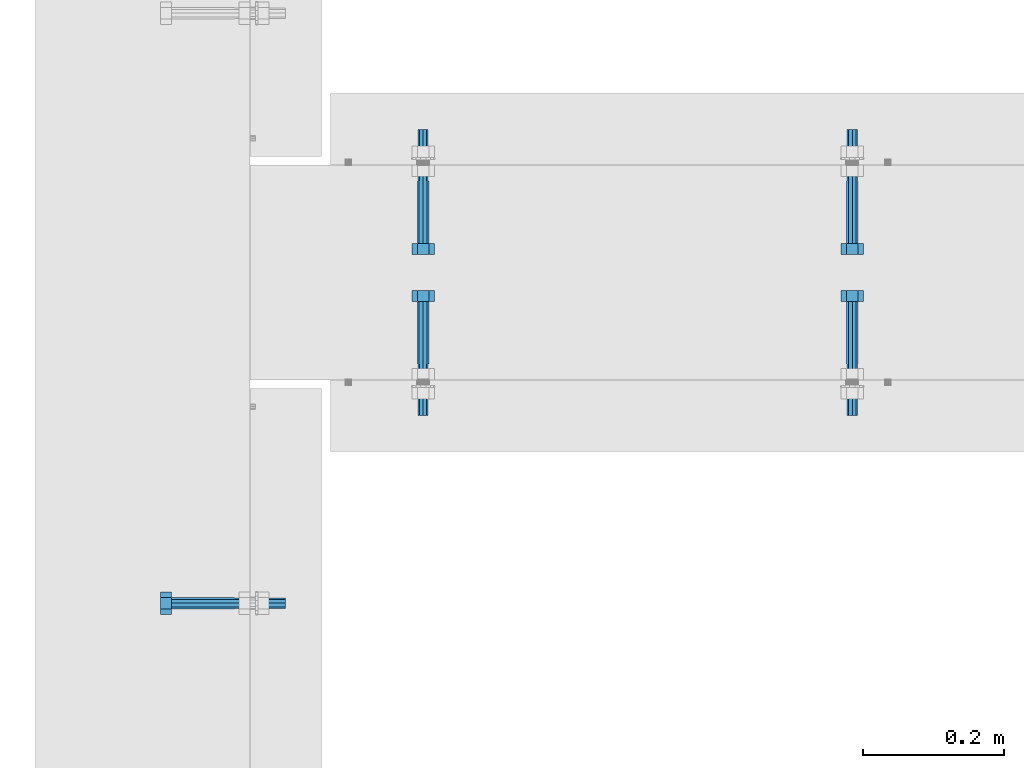
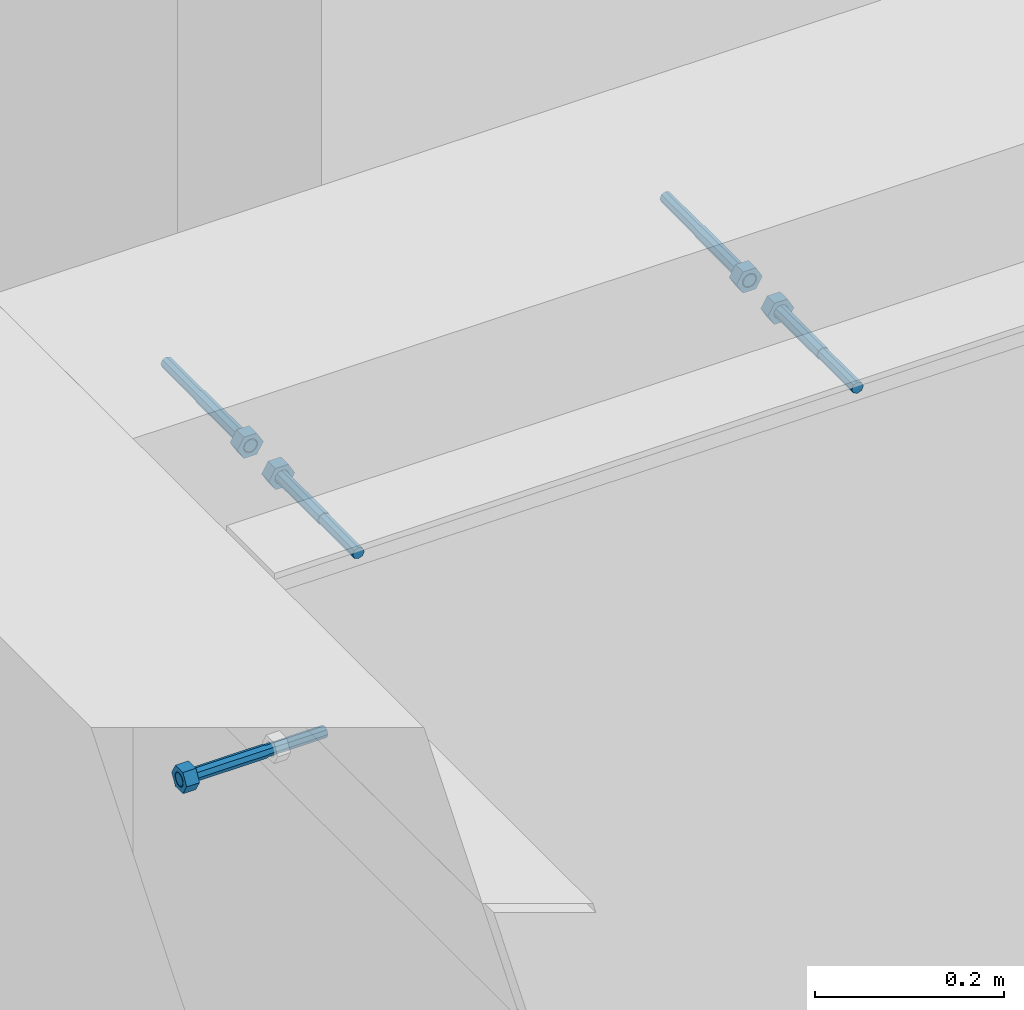
# One storey, part 420 of 975: 5 beams.
"""IFC2X3 building model written with IfcOpenShell, lengths in millimetres."""

from ifc_helpers import new_model, si_unit, frame, origin_with_axes, place, context, subcontext, project, spatial, faceted_brep, material, type_object, element, save


model = new_model("IFC2X3")

# Units and contexts
model_context = context("Model", 3, precision=1e-05, world=origin_with_axes())
body_context = subcontext(model_context, "Body", "Model", "MODEL_VIEW")
ifc_project = project(units=[si_unit("LENGTHUNIT", "METRE", prefix="MILLI"), si_unit("AREAUNIT", "SQUARE_METRE"), si_unit("VOLUMEUNIT", "CUBIC_METRE"), si_unit("MASSUNIT", "GRAM", prefix="KILO"), si_unit("TIMEUNIT", "SECOND"), si_unit("PLANEANGLEUNIT", "RADIAN"), si_unit("SOLIDANGLEUNIT", "STERADIAN"), si_unit("THERMODYNAMICTEMPERATUREUNIT", "DEGREE_CELSIUS"), si_unit("LUMINOUSINTENSITYUNIT", "LUMEN")], contexts=[model_context])

# Site, building, storey
site_placement = place(None, origin_with_axes())
site = spatial("IfcSite", under=ifc_project, at=site_placement, CompositionType="ELEMENT")
building_placement = place(site_placement, origin_with_axes())
building = spatial("IfcBuilding", under=site, at=building_placement, Name="Undefined", CompositionType="ELEMENT")
storey_placement = place(building_placement, origin_with_axes())
storey = spatial("IfcBuildingStorey", under=building, at=storey_placement, Name="Undefined", CompositionType="ELEMENT", Elevation=0.0)

# Beams
ifc_material = material(Name="STEEL/F1554-36")
beam_type = type_object("IfcBeamType", PredefinedType="NOTDEFINED")
beam_1_placement = place(storey_placement, frame((282.574949105307, 17560.9249021777, 3835.4), z_axis=(0.0, 0.0, -1.0), x_axis=(-0.999999999999998, 6.90000001668524e-08, 0.0)))
element("IfcBeam", 1, at=beam_1_placement, inside=storey, type_object=beam_type, material=ifc_material, Name="HEADED_ANCHOR_BOLT", context=body_context, shape_type="Brep", body=[
    faceted_brep([(88.9000000184824, 7.94000001861696, -13.7499999799138), (88.8999999527368, 15.8800000758411, 2.00943759409711e-08), (104.774999952569, 15.8800001213949, 6.97191353538074e-08), (104.775000018315, 7.94000006417082, -13.7499999302891), (88.900000064019, -7.94000009583215, -13.7499999799147), (104.775000063852, -7.9400000502792, -13.74999993029), (88.9000000438027, -15.880000153059, 2.00925569515675e-08), (104.775000043643, -15.8800001075042, 6.9716406869702e-08), (88.8999999780608, -7.94000009583488, 13.7500000200998), (104.774999977893, -7.94000005028101, 13.7500000697237), (88.8999999325279, 7.94000001861514, 13.7500000201007), (104.774999932361, 7.940000064169, 13.7500000697246), (88.9000000119959, 3.78780480527439, -7.86545778426807), (88.8999999957159, 6.82538844544797, -5.4430656647246), (88.8999999799416, 8.51112018845743, -1.94260763148395), (88.8999999677944, 8.51112018845652, 1.94260767167179), (88.8999999616899, 6.82538844544615, 5.44306570491244), (88.8999999628249, 3.78780480527257, 7.86545782445592), (88.8999999709849, -3.86089595849626e-08, 8.72999956233434), (88.8999999845473, -3.7878048824914, 7.8654578244541), (88.9000000008309, -6.82538852266407, 5.44306570491153), (88.9000000166052, -8.51112026567444, 1.94260767166998), (88.9000000287488, -8.51112026567353, -1.94260763148577), (88.9000000348606, -6.82538852266407, -5.44306566472642), (88.9000000337182, -3.78780488248958, -7.86545778426898), (88.9000000255583, -3.86080500902608e-08, -8.72999952214832), (104.775000025395, 6.94581103743985e-09, -8.72999947252447), (104.775000011829, 3.78780485082825, -7.86545773464422), (104.774999995549, 6.82538849100092, -5.44306561510075), (104.774999979774, 8.51112023401038, -1.9426075818601), (104.774999967627, 8.51112023401038, 1.94260772129564), (104.774999961523, 6.82538849100092, 5.44306575453629), (104.774999962658, 3.78780485082643, 7.86545787407977), (104.774999970818, 6.94399204803631e-09, 8.7299996119591), (104.77499998438, -3.78780483693754, 7.86545787407886), (104.775000000664, -6.82538847711112, 5.44306575453538), (104.775000016438, -8.51112022012057, 1.94260772129473), (104.775000028581, -8.51112022012057, -1.94260758186101), (104.775000034693, -6.82538847711021, -5.44306561510166), (104.775000033551, -3.78780483693663, -7.86545773464422), (-2.99107341561466e-07, -5.61266007567065, 5.61266007566792), (-4.22995071858168e-07, -7.93750000000728, 0.0), (104.774999998088, -7.93749999999, -4.45652403868735e-11), (104.774999998088, -5.61266007565791, 5.61266007562426), (-1.09139364212751e-11, 1.81898940354586e-12, 7.9375), (104.774999998095, 1.18234311230481e-11, 7.93749999995816), (2.99089151667431e-07, 5.61266007567428, 5.61266007566792), (104.774999998102, 5.61266007568065, 5.61266007562517), (4.22980519942939e-07, 7.93750000001091, 0.0), (104.77499999811, 7.93750000001364, -4.36557456851006e-11), (2.99089151667431e-07, 5.61266007567428, -5.61266007566792), (104.774999998102, 5.61266007568156, -5.61266007571339), (-1.09139364212751e-11, 1.81898940354586e-12, -7.9375), (104.774999998099, 1.2732925824821e-11, -7.93750000004547), (-73.0249999592124, 5.05157065939329, -5.0515715445581), (-73.0249999269472, -1.85405951924622e-07, -7.14400069976364), (-73.0249999328516, -5.0515710302052, -5.05157154455992), (-73.0249999734697, -7.14400018541073, -6.9975976657588e-07), (-73.0250000250016, -5.05157103020611, 5.05157014504039), (-73.0250000572705, -1.85406861419324e-07, 7.1439993002441), (-73.0250000513661, 5.05157065939238, 5.05157014503948), (-73.025000010748, 7.14399981459792, -6.99758857081179e-07), (0.00625003290042514, 5.05157085007795, -5.05157087849238), (0.00625006516929716, 5.27870724909008e-09, -7.1440000336961), (0.00625005926485755, -5.05157083952145, -5.05157087849329), (0.00625001864682417, -7.14399999472516, -3.36940502165817e-08), (0.00624996711121639, -5.05157083952145, 5.05157081110519), (0.00624993484598235, 5.2777977543883e-09, 7.14399996631164), (0.00624994074678398, 5.05157085007704, 5.05157081110701), (0.00624998136845534, 7.14400000528167, -3.36922312271781e-08), (-2.99107341561466e-07, -5.61266007567065, -5.61266007566792), (104.774999998092, -5.612660075657, -5.6126600757143)], [[[0, 1, 2, 3]], [[4, 0, 3, 5]], [[6, 4, 5, 7]], [[8, 6, 7, 9]], [[10, 8, 9, 11]], [[0, 4, 6, 8, 10, 1], [12, 13, 14, 15, 16, 17, 18, 19, 20, 21, 22, 23, 24, 25]], [[12, 25, 26, 27]], [[13, 12, 27, 28]], [[14, 13, 28, 29]], [[15, 14, 29, 30]], [[16, 15, 30, 31]], [[17, 16, 31, 32]], [[18, 17, 32, 33]], [[19, 18, 33, 34]], [[20, 19, 34, 35]], [[21, 20, 35, 36]], [[22, 21, 36, 37]], [[23, 22, 37, 38]], [[24, 23, 38, 39]], [[25, 24, 39, 26]], [[9, 7, 5, 3, 2, 11], [38, 37, 36, 35, 34, 33, 32, 31, 30, 29, 28, 27, 26, 39]], [[1, 10, 11, 2]], [[40, 41, 42, 43]], [[44, 40, 43, 45]], [[46, 44, 45, 47]], [[48, 46, 47, 49]], [[50, 48, 49, 51]], [[52, 50, 51, 53]], [[54, 55, 56, 57, 58, 59, 60, 61]], [[55, 54, 62, 63]], [[56, 55, 63, 64]], [[57, 56, 64, 65]], [[58, 57, 65, 66]], [[59, 58, 66, 67]], [[60, 59, 67, 68]], [[61, 60, 68, 69]], [[54, 61, 69, 62]], [[40, 44, 46, 48, 50, 52, 70, 41], [68, 67, 66, 65, 64, 63, 62, 69]], [[41, 70, 71, 42]], [[53, 51, 49, 47, 45, 43, 42, 71]], [[70, 52, 53, 71]]]),
])
beam_2_placement = place(storey_placement, frame((1160.46250032314, 18160.9999997141, 3835.4), z_axis=(0.0, 0.0, 1.0), x_axis=(0.0, -1.0, 0.0)))
element("IfcBeam", 2, at=beam_2_placement, inside=storey, type_object=beam_type, material=ifc_material, Name="HEADED_ANCHOR_BOLT", context=body_context, shape_type="Brep", body=[
    faceted_brep([(88.9000000184824, 7.94000001861696, -13.7499999799138), (88.8999999527368, 15.8800000758411, 2.00943759409711e-08), (104.774999952569, 15.8800001213949, 6.97191353538074e-08), (104.775000018315, 7.94000006417082, -13.7499999302891), (88.900000064019, -7.94000009583215, -13.7499999799147), (104.775000063852, -7.9400000502792, -13.74999993029), (88.9000000438027, -15.880000153059, 2.00925569515675e-08), (104.775000043643, -15.8800001075042, 6.9716406869702e-08), (88.8999999780608, -7.94000009583488, 13.7500000200998), (104.774999977893, -7.94000005028101, 13.7500000697237), (88.8999999325279, 7.94000001861514, 13.7500000201007), (104.774999932361, 7.940000064169, 13.7500000697246), (88.9000000119959, 3.78780480527439, -7.86545778426807), (88.8999999957159, 6.82538844544797, -5.4430656647246), (88.8999999799416, 8.51112018845743, -1.94260763148395), (88.8999999677944, 8.51112018845652, 1.94260767167179), (88.8999999616899, 6.82538844544615, 5.44306570491244), (88.8999999628249, 3.78780480527257, 7.86545782445592), (88.8999999709849, -3.86089595849626e-08, 8.72999956233434), (88.8999999845473, -3.7878048824914, 7.8654578244541), (88.9000000008309, -6.82538852266407, 5.44306570491153), (88.9000000166052, -8.51112026567444, 1.94260767166998), (88.9000000287488, -8.51112026567353, -1.94260763148577), (88.9000000348606, -6.82538852266407, -5.44306566472642), (88.9000000337182, -3.78780488248958, -7.86545778426898), (88.9000000255583, -3.86080500902608e-08, -8.72999952214832), (104.775000025395, 6.94581103743985e-09, -8.72999947252447), (104.775000011829, 3.78780485082825, -7.86545773464422), (104.774999995549, 6.82538849100092, -5.44306561510075), (104.774999979774, 8.51112023401038, -1.9426075818601), (104.774999967627, 8.51112023401038, 1.94260772129564), (104.774999961523, 6.82538849100092, 5.44306575453629), (104.774999962658, 3.78780485082643, 7.86545787407977), (104.774999970818, 6.94399204803631e-09, 8.7299996119591), (104.77499998438, -3.78780483693754, 7.86545787407886), (104.775000000664, -6.82538847711112, 5.44306575453538), (104.775000016438, -8.51112022012057, 1.94260772129473), (104.775000028581, -8.51112022012057, -1.94260758186101), (104.775000034693, -6.82538847711021, -5.44306561510166), (104.775000033551, -3.78780483693663, -7.86545773464422), (-2.99107341561466e-07, -5.61266007567065, 5.61266007566792), (-4.22995071858168e-07, -7.93750000000728, 0.0), (104.774999998088, -7.93749999999, -4.45652403868735e-11), (104.774999998088, -5.61266007565791, 5.61266007562426), (-1.09139364212751e-11, 1.81898940354586e-12, 7.9375), (104.774999998095, 1.18234311230481e-11, 7.93749999995816), (2.99089151667431e-07, 5.61266007567428, 5.61266007566792), (104.774999998102, 5.61266007568065, 5.61266007562517), (4.22980519942939e-07, 7.93750000001091, 0.0), (104.77499999811, 7.93750000001364, -4.36557456851006e-11), (2.99089151667431e-07, 5.61266007567428, -5.61266007566792), (104.774999998102, 5.61266007568156, -5.61266007571339), (-1.09139364212751e-11, 1.81898940354586e-12, -7.9375), (104.774999998099, 1.2732925824821e-11, -7.93750000004547), (-73.0249999592124, 5.05157065939329, -5.0515715445581), (-73.0249999269472, -1.85405951924622e-07, -7.14400069976364), (-73.0249999328516, -5.0515710302052, -5.05157154455992), (-73.0249999734697, -7.14400018541073, -6.9975976657588e-07), (-73.0250000250016, -5.05157103020611, 5.05157014504039), (-73.0250000572705, -1.85406861419324e-07, 7.1439993002441), (-73.0250000513661, 5.05157065939238, 5.05157014503948), (-73.025000010748, 7.14399981459792, -6.99758857081179e-07), (0.00625003290042514, 5.05157085007795, -5.05157087849238), (0.00625006516929716, 5.27870724909008e-09, -7.1440000336961), (0.00625005926485755, -5.05157083952145, -5.05157087849329), (0.00625001864682417, -7.14399999472516, -3.36940502165817e-08), (0.00624996711121639, -5.05157083952145, 5.05157081110519), (0.00624993484598235, 5.2777977543883e-09, 7.14399996631164), (0.00624994074678398, 5.05157085007704, 5.05157081110701), (0.00624998136845534, 7.14400000528167, -3.36922312271781e-08), (-2.99107341561466e-07, -5.61266007567065, -5.61266007566792), (104.774999998092, -5.612660075657, -5.6126600757143)], [[[0, 1, 2, 3]], [[4, 0, 3, 5]], [[6, 4, 5, 7]], [[8, 6, 7, 9]], [[10, 8, 9, 11]], [[0, 4, 6, 8, 10, 1], [12, 13, 14, 15, 16, 17, 18, 19, 20, 21, 22, 23, 24, 25]], [[12, 25, 26, 27]], [[13, 12, 27, 28]], [[14, 13, 28, 29]], [[15, 14, 29, 30]], [[16, 15, 30, 31]], [[17, 16, 31, 32]], [[18, 17, 32, 33]], [[19, 18, 33, 34]], [[20, 19, 34, 35]], [[21, 20, 35, 36]], [[22, 21, 36, 37]], [[23, 22, 37, 38]], [[24, 23, 38, 39]], [[25, 24, 39, 26]], [[9, 7, 5, 3, 2, 11], [38, 37, 36, 35, 34, 33, 32, 31, 30, 29, 28, 27, 26, 39]], [[1, 10, 11, 2]], [[40, 41, 42, 43]], [[44, 40, 43, 45]], [[46, 44, 45, 47]], [[48, 46, 47, 49]], [[50, 48, 49, 51]], [[52, 50, 51, 53]], [[54, 55, 56, 57, 58, 59, 60, 61]], [[55, 54, 62, 63]], [[56, 55, 63, 64]], [[57, 56, 64, 65]], [[58, 57, 65, 66]], [[59, 58, 66, 67]], [[60, 59, 67, 68]], [[61, 60, 68, 69]], [[54, 61, 69, 62]], [[40, 44, 46, 48, 50, 52, 70, 41], [68, 67, 66, 65, 64, 63, 62, 69]], [[41, 70, 71, 42]], [[53, 51, 49, 47, 45, 43, 42, 71]], [[70, 52, 53, 71]]]),
])
beam_3_placement = place(storey_placement, frame((550.862524737206, 18160.9999997141, 3835.4), z_axis=(0.0, 0.0, -1.0), x_axis=(0.0, -1.0, 0.0)))
element("IfcBeam", 3, at=beam_3_placement, inside=storey, type_object=beam_type, material=ifc_material, Name="HEADED_ANCHOR_BOLT", context=body_context, shape_type="Brep", body=[
    faceted_brep([(88.9000000184824, 7.94000001861696, -13.7499999799138), (88.8999999527368, 15.8800000758411, 2.00943759409711e-08), (104.774999952569, 15.8800001213949, 6.97191353538074e-08), (104.775000018315, 7.94000006417082, -13.7499999302891), (88.900000064019, -7.94000009583215, -13.7499999799147), (104.775000063852, -7.9400000502792, -13.74999993029), (88.9000000438027, -15.880000153059, 2.00925569515675e-08), (104.775000043643, -15.8800001075042, 6.9716406869702e-08), (88.8999999780608, -7.94000009583488, 13.7500000200998), (104.774999977893, -7.94000005028101, 13.7500000697237), (88.8999999325279, 7.94000001861514, 13.7500000201007), (104.774999932361, 7.940000064169, 13.7500000697246), (88.9000000119959, 3.78780480527439, -7.86545778426807), (88.8999999957159, 6.82538844544797, -5.4430656647246), (88.8999999799416, 8.51112018845743, -1.94260763148395), (88.8999999677944, 8.51112018845652, 1.94260767167179), (88.8999999616899, 6.82538844544615, 5.44306570491244), (88.8999999628249, 3.78780480527257, 7.86545782445592), (88.8999999709849, -3.86089595849626e-08, 8.72999956233434), (88.8999999845473, -3.7878048824914, 7.8654578244541), (88.9000000008309, -6.82538852266407, 5.44306570491153), (88.9000000166052, -8.51112026567444, 1.94260767166998), (88.9000000287488, -8.51112026567353, -1.94260763148577), (88.9000000348606, -6.82538852266407, -5.44306566472642), (88.9000000337182, -3.78780488248958, -7.86545778426898), (88.9000000255583, -3.86080500902608e-08, -8.72999952214832), (104.775000025395, 6.94581103743985e-09, -8.72999947252447), (104.775000011829, 3.78780485082825, -7.86545773464422), (104.774999995549, 6.82538849100092, -5.44306561510075), (104.774999979774, 8.51112023401038, -1.9426075818601), (104.774999967627, 8.51112023401038, 1.94260772129564), (104.774999961523, 6.82538849100092, 5.44306575453629), (104.774999962658, 3.78780485082643, 7.86545787407977), (104.774999970818, 6.94399204803631e-09, 8.7299996119591), (104.77499998438, -3.78780483693754, 7.86545787407886), (104.775000000664, -6.82538847711112, 5.44306575453538), (104.775000016438, -8.51112022012057, 1.94260772129473), (104.775000028581, -8.51112022012057, -1.94260758186101), (104.775000034693, -6.82538847711021, -5.44306561510166), (104.775000033551, -3.78780483693663, -7.86545773464422), (-2.99107341561466e-07, -5.61266007567065, 5.61266007566792), (-4.22995071858168e-07, -7.93750000000728, 0.0), (104.774999998088, -7.93749999999, -4.45652403868735e-11), (104.774999998088, -5.61266007565791, 5.61266007562426), (-1.09139364212751e-11, 1.81898940354586e-12, 7.9375), (104.774999998095, 1.18234311230481e-11, 7.93749999995816), (2.99089151667431e-07, 5.61266007567428, 5.61266007566792), (104.774999998102, 5.61266007568065, 5.61266007562517), (4.22980519942939e-07, 7.93750000001091, 0.0), (104.77499999811, 7.93750000001364, -4.36557456851006e-11), (2.99089151667431e-07, 5.61266007567428, -5.61266007566792), (104.774999998102, 5.61266007568156, -5.61266007571339), (-1.09139364212751e-11, 1.81898940354586e-12, -7.9375), (104.774999998099, 1.2732925824821e-11, -7.93750000004547), (-73.0249999592124, 5.05157065939329, -5.0515715445581), (-73.0249999269472, -1.85405951924622e-07, -7.14400069976364), (-73.0249999328516, -5.0515710302052, -5.05157154455992), (-73.0249999734697, -7.14400018541073, -6.9975976657588e-07), (-73.0250000250016, -5.05157103020611, 5.05157014504039), (-73.0250000572705, -1.85406861419324e-07, 7.1439993002441), (-73.0250000513661, 5.05157065939238, 5.05157014503948), (-73.025000010748, 7.14399981459792, -6.99758857081179e-07), (0.00625003290042514, 5.05157085007795, -5.05157087849238), (0.00625006516929716, 5.27870724909008e-09, -7.1440000336961), (0.00625005926485755, -5.05157083952145, -5.05157087849329), (0.00625001864682417, -7.14399999472516, -3.36940502165817e-08), (0.00624996711121639, -5.05157083952145, 5.05157081110519), (0.00624993484598235, 5.2777977543883e-09, 7.14399996631164), (0.00624994074678398, 5.05157085007704, 5.05157081110701), (0.00624998136845534, 7.14400000528167, -3.36922312271781e-08), (-2.99107341561466e-07, -5.61266007567065, -5.61266007566792), (104.774999998092, -5.612660075657, -5.6126600757143)], [[[0, 1, 2, 3]], [[4, 0, 3, 5]], [[6, 4, 5, 7]], [[8, 6, 7, 9]], [[10, 8, 9, 11]], [[0, 4, 6, 8, 10, 1], [12, 13, 14, 15, 16, 17, 18, 19, 20, 21, 22, 23, 24, 25]], [[12, 25, 26, 27]], [[13, 12, 27, 28]], [[14, 13, 28, 29]], [[15, 14, 29, 30]], [[16, 15, 30, 31]], [[17, 16, 31, 32]], [[18, 17, 32, 33]], [[19, 18, 33, 34]], [[20, 19, 34, 35]], [[21, 20, 35, 36]], [[22, 21, 36, 37]], [[23, 22, 37, 38]], [[24, 23, 38, 39]], [[25, 24, 39, 26]], [[9, 7, 5, 3, 2, 11], [38, 37, 36, 35, 34, 33, 32, 31, 30, 29, 28, 27, 26, 39]], [[1, 10, 11, 2]], [[40, 41, 42, 43]], [[44, 40, 43, 45]], [[46, 44, 45, 47]], [[48, 46, 47, 49]], [[50, 48, 49, 51]], [[52, 50, 51, 53]], [[54, 55, 56, 57, 58, 59, 60, 61]], [[55, 54, 62, 63]], [[56, 55, 63, 64]], [[57, 56, 64, 65]], [[58, 57, 65, 66]], [[59, 58, 66, 67]], [[60, 59, 67, 68]], [[61, 60, 68, 69]], [[54, 61, 69, 62]], [[40, 44, 46, 48, 50, 52, 70, 41], [68, 67, 66, 65, 64, 63, 62, 69]], [[41, 70, 71, 42]], [[53, 51, 49, 47, 45, 43, 42, 71]], [[70, 52, 53, 71]]]),
])
beam_4_placement = place(storey_placement, frame((1160.46250032314, 17900.65, 3835.4), z_axis=(0.0, 0.0, -1.0), x_axis=(0.0, 1.0, 0.0)))
element("IfcBeam", 4, at=beam_4_placement, inside=storey, type_object=beam_type, material=ifc_material, Name="HEADED_ANCHOR_BOLT", context=body_context, shape_type="Brep", body=[
    faceted_brep([(88.9000000184824, 7.94000001861696, -13.7499999799138), (88.8999999527368, 15.8800000758411, 2.00943759409711e-08), (104.774999952569, 15.8800001213949, 6.97191353538074e-08), (104.775000018315, 7.94000006417082, -13.7499999302891), (88.900000064019, -7.94000009583215, -13.7499999799147), (104.775000063852, -7.9400000502792, -13.74999993029), (88.9000000438027, -15.880000153059, 2.00925569515675e-08), (104.775000043643, -15.8800001075042, 6.9716406869702e-08), (88.8999999780608, -7.94000009583488, 13.7500000200998), (104.774999977893, -7.94000005028101, 13.7500000697237), (88.8999999325279, 7.94000001861514, 13.7500000201007), (104.774999932361, 7.940000064169, 13.7500000697246), (88.9000000119959, 3.78780480527439, -7.86545778426807), (88.8999999957159, 6.82538844544797, -5.4430656647246), (88.8999999799416, 8.51112018845743, -1.94260763148395), (88.8999999677944, 8.51112018845652, 1.94260767167179), (88.8999999616899, 6.82538844544615, 5.44306570491244), (88.8999999628249, 3.78780480527257, 7.86545782445592), (88.8999999709849, -3.86089595849626e-08, 8.72999956233434), (88.8999999845473, -3.7878048824914, 7.8654578244541), (88.9000000008309, -6.82538852266407, 5.44306570491153), (88.9000000166052, -8.51112026567444, 1.94260767166998), (88.9000000287488, -8.51112026567353, -1.94260763148577), (88.9000000348606, -6.82538852266407, -5.44306566472642), (88.9000000337182, -3.78780488248958, -7.86545778426898), (88.9000000255583, -3.86080500902608e-08, -8.72999952214832), (104.775000025395, 6.94581103743985e-09, -8.72999947252447), (104.775000011829, 3.78780485082825, -7.86545773464422), (104.774999995549, 6.82538849100092, -5.44306561510075), (104.774999979774, 8.51112023401038, -1.9426075818601), (104.774999967627, 8.51112023401038, 1.94260772129564), (104.774999961523, 6.82538849100092, 5.44306575453629), (104.774999962658, 3.78780485082643, 7.86545787407977), (104.774999970818, 6.94399204803631e-09, 8.7299996119591), (104.77499998438, -3.78780483693754, 7.86545787407886), (104.775000000664, -6.82538847711112, 5.44306575453538), (104.775000016438, -8.51112022012057, 1.94260772129473), (104.775000028581, -8.51112022012057, -1.94260758186101), (104.775000034693, -6.82538847711021, -5.44306561510166), (104.775000033551, -3.78780483693663, -7.86545773464422), (-2.99107341561466e-07, -5.61266007567065, 5.61266007566792), (-4.22995071858168e-07, -7.93750000000728, 0.0), (104.774999998088, -7.93749999999, -4.45652403868735e-11), (104.774999998088, -5.61266007565791, 5.61266007562426), (-1.09139364212751e-11, 1.81898940354586e-12, 7.9375), (104.774999998095, 1.18234311230481e-11, 7.93749999995816), (2.99089151667431e-07, 5.61266007567428, 5.61266007566792), (104.774999998102, 5.61266007568065, 5.61266007562517), (4.22980519942939e-07, 7.93750000001091, 0.0), (104.77499999811, 7.93750000001364, -4.36557456851006e-11), (2.99089151667431e-07, 5.61266007567428, -5.61266007566792), (104.774999998102, 5.61266007568156, -5.61266007571339), (-1.09139364212751e-11, 1.81898940354586e-12, -7.9375), (104.774999998099, 1.2732925824821e-11, -7.93750000004547), (-73.0249999592124, 5.05157065939329, -5.0515715445581), (-73.0249999269472, -1.85405951924622e-07, -7.14400069976364), (-73.0249999328516, -5.0515710302052, -5.05157154455992), (-73.0249999734697, -7.14400018541073, -6.9975976657588e-07), (-73.0250000250016, -5.05157103020611, 5.05157014504039), (-73.0250000572705, -1.85406861419324e-07, 7.1439993002441), (-73.0250000513661, 5.05157065939238, 5.05157014503948), (-73.025000010748, 7.14399981459792, -6.99758857081179e-07), (0.00625003290042514, 5.05157085007795, -5.05157087849238), (0.00625006516929716, 5.27870724909008e-09, -7.1440000336961), (0.00625005926485755, -5.05157083952145, -5.05157087849329), (0.00625001864682417, -7.14399999472516, -3.36940502165817e-08), (0.00624996711121639, -5.05157083952145, 5.05157081110519), (0.00624993484598235, 5.2777977543883e-09, 7.14399996631164), (0.00624994074678398, 5.05157085007704, 5.05157081110701), (0.00624998136845534, 7.14400000528167, -3.36922312271781e-08), (-2.99107341561466e-07, -5.61266007567065, -5.61266007566792), (104.774999998092, -5.612660075657, -5.6126600757143)], [[[0, 1, 2, 3]], [[4, 0, 3, 5]], [[6, 4, 5, 7]], [[8, 6, 7, 9]], [[10, 8, 9, 11]], [[0, 4, 6, 8, 10, 1], [12, 13, 14, 15, 16, 17, 18, 19, 20, 21, 22, 23, 24, 25]], [[12, 25, 26, 27]], [[13, 12, 27, 28]], [[14, 13, 28, 29]], [[15, 14, 29, 30]], [[16, 15, 30, 31]], [[17, 16, 31, 32]], [[18, 17, 32, 33]], [[19, 18, 33, 34]], [[20, 19, 34, 35]], [[21, 20, 35, 36]], [[22, 21, 36, 37]], [[23, 22, 37, 38]], [[24, 23, 38, 39]], [[25, 24, 39, 26]], [[9, 7, 5, 3, 2, 11], [38, 37, 36, 35, 34, 33, 32, 31, 30, 29, 28, 27, 26, 39]], [[1, 10, 11, 2]], [[40, 41, 42, 43]], [[44, 40, 43, 45]], [[46, 44, 45, 47]], [[48, 46, 47, 49]], [[50, 48, 49, 51]], [[52, 50, 51, 53]], [[54, 55, 56, 57, 58, 59, 60, 61]], [[55, 54, 62, 63]], [[56, 55, 63, 64]], [[57, 56, 64, 65]], [[58, 57, 65, 66]], [[59, 58, 66, 67]], [[60, 59, 67, 68]], [[61, 60, 68, 69]], [[54, 61, 69, 62]], [[40, 44, 46, 48, 50, 52, 70, 41], [68, 67, 66, 65, 64, 63, 62, 69]], [[41, 70, 71, 42]], [[53, 51, 49, 47, 45, 43, 42, 71]], [[70, 52, 53, 71]]]),
])
beam_5_placement = place(storey_placement, frame((550.862524737206, 17900.65, 3835.4), z_axis=(0.0, 0.0, 1.0), x_axis=(0.0, 1.0, 0.0)))
element("IfcBeam", 5, at=beam_5_placement, inside=storey, type_object=beam_type, material=ifc_material, Name="HEADED_ANCHOR_BOLT", context=body_context, shape_type="Brep", body=[
    faceted_brep([(88.9000000184824, 7.94000001861696, -13.7499999799138), (88.8999999527368, 15.8800000758411, 2.00943759409711e-08), (104.774999952569, 15.8800001213949, 6.97191353538074e-08), (104.775000018315, 7.94000006417082, -13.7499999302891), (88.900000064019, -7.94000009583215, -13.7499999799147), (104.775000063852, -7.9400000502792, -13.74999993029), (88.9000000438027, -15.880000153059, 2.00925569515675e-08), (104.775000043643, -15.8800001075042, 6.9716406869702e-08), (88.8999999780608, -7.94000009583488, 13.7500000200998), (104.774999977893, -7.94000005028101, 13.7500000697237), (88.8999999325279, 7.94000001861514, 13.7500000201007), (104.774999932361, 7.940000064169, 13.7500000697246), (88.9000000119959, 3.78780480527439, -7.86545778426807), (88.8999999957159, 6.82538844544797, -5.4430656647246), (88.8999999799416, 8.51112018845743, -1.94260763148395), (88.8999999677944, 8.51112018845652, 1.94260767167179), (88.8999999616899, 6.82538844544615, 5.44306570491244), (88.8999999628249, 3.78780480527257, 7.86545782445592), (88.8999999709849, -3.86089595849626e-08, 8.72999956233434), (88.8999999845473, -3.7878048824914, 7.8654578244541), (88.9000000008309, -6.82538852266407, 5.44306570491153), (88.9000000166052, -8.51112026567444, 1.94260767166998), (88.9000000287488, -8.51112026567353, -1.94260763148577), (88.9000000348606, -6.82538852266407, -5.44306566472642), (88.9000000337182, -3.78780488248958, -7.86545778426898), (88.9000000255583, -3.86080500902608e-08, -8.72999952214832), (104.775000025395, 6.94581103743985e-09, -8.72999947252447), (104.775000011829, 3.78780485082825, -7.86545773464422), (104.774999995549, 6.82538849100092, -5.44306561510075), (104.774999979774, 8.51112023401038, -1.9426075818601), (104.774999967627, 8.51112023401038, 1.94260772129564), (104.774999961523, 6.82538849100092, 5.44306575453629), (104.774999962658, 3.78780485082643, 7.86545787407977), (104.774999970818, 6.94399204803631e-09, 8.7299996119591), (104.77499998438, -3.78780483693754, 7.86545787407886), (104.775000000664, -6.82538847711112, 5.44306575453538), (104.775000016438, -8.51112022012057, 1.94260772129473), (104.775000028581, -8.51112022012057, -1.94260758186101), (104.775000034693, -6.82538847711021, -5.44306561510166), (104.775000033551, -3.78780483693663, -7.86545773464422), (-2.99107341561466e-07, -5.61266007567065, 5.61266007566792), (-4.22995071858168e-07, -7.93750000000728, 0.0), (104.774999998088, -7.93749999999, -4.45652403868735e-11), (104.774999998088, -5.61266007565791, 5.61266007562426), (-1.09139364212751e-11, 1.81898940354586e-12, 7.9375), (104.774999998095, 1.18234311230481e-11, 7.93749999995816), (2.99089151667431e-07, 5.61266007567428, 5.61266007566792), (104.774999998102, 5.61266007568065, 5.61266007562517), (4.22980519942939e-07, 7.93750000001091, 0.0), (104.77499999811, 7.93750000001364, -4.36557456851006e-11), (2.99089151667431e-07, 5.61266007567428, -5.61266007566792), (104.774999998102, 5.61266007568156, -5.61266007571339), (-1.09139364212751e-11, 1.81898940354586e-12, -7.9375), (104.774999998099, 1.2732925824821e-11, -7.93750000004547), (-73.0249999592124, 5.05157065939329, -5.0515715445581), (-73.0249999269472, -1.85405951924622e-07, -7.14400069976364), (-73.0249999328516, -5.0515710302052, -5.05157154455992), (-73.0249999734697, -7.14400018541073, -6.9975976657588e-07), (-73.0250000250016, -5.05157103020611, 5.05157014504039), (-73.0250000572705, -1.85406861419324e-07, 7.1439993002441), (-73.0250000513661, 5.05157065939238, 5.05157014503948), (-73.025000010748, 7.14399981459792, -6.99758857081179e-07), (0.00625003290042514, 5.05157085007795, -5.05157087849238), (0.00625006516929716, 5.27870724909008e-09, -7.1440000336961), (0.00625005926485755, -5.05157083952145, -5.05157087849329), (0.00625001864682417, -7.14399999472516, -3.36940502165817e-08), (0.00624996711121639, -5.05157083952145, 5.05157081110519), (0.00624993484598235, 5.2777977543883e-09, 7.14399996631164), (0.00624994074678398, 5.05157085007704, 5.05157081110701), (0.00624998136845534, 7.14400000528167, -3.36922312271781e-08), (-2.99107341561466e-07, -5.61266007567065, -5.61266007566792), (104.774999998092, -5.612660075657, -5.6126600757143)], [[[0, 1, 2, 3]], [[4, 0, 3, 5]], [[6, 4, 5, 7]], [[8, 6, 7, 9]], [[10, 8, 9, 11]], [[0, 4, 6, 8, 10, 1], [12, 13, 14, 15, 16, 17, 18, 19, 20, 21, 22, 23, 24, 25]], [[12, 25, 26, 27]], [[13, 12, 27, 28]], [[14, 13, 28, 29]], [[15, 14, 29, 30]], [[16, 15, 30, 31]], [[17, 16, 31, 32]], [[18, 17, 32, 33]], [[19, 18, 33, 34]], [[20, 19, 34, 35]], [[21, 20, 35, 36]], [[22, 21, 36, 37]], [[23, 22, 37, 38]], [[24, 23, 38, 39]], [[25, 24, 39, 26]], [[9, 7, 5, 3, 2, 11], [38, 37, 36, 35, 34, 33, 32, 31, 30, 29, 28, 27, 26, 39]], [[1, 10, 11, 2]], [[40, 41, 42, 43]], [[44, 40, 43, 45]], [[46, 44, 45, 47]], [[48, 46, 47, 49]], [[50, 48, 49, 51]], [[52, 50, 51, 53]], [[54, 55, 56, 57, 58, 59, 60, 61]], [[55, 54, 62, 63]], [[56, 55, 63, 64]], [[57, 56, 64, 65]], [[58, 57, 65, 66]], [[59, 58, 66, 67]], [[60, 59, 67, 68]], [[61, 60, 68, 69]], [[54, 61, 69, 62]], [[40, 44, 46, 48, 50, 52, 70, 41], [68, 67, 66, 65, 64, 63, 62, 69]], [[41, 70, 71, 42]], [[53, 51, 49, 47, 45, 43, 42, 71]], [[70, 52, 53, 71]]]),
])

save(model, "model.ifc")
